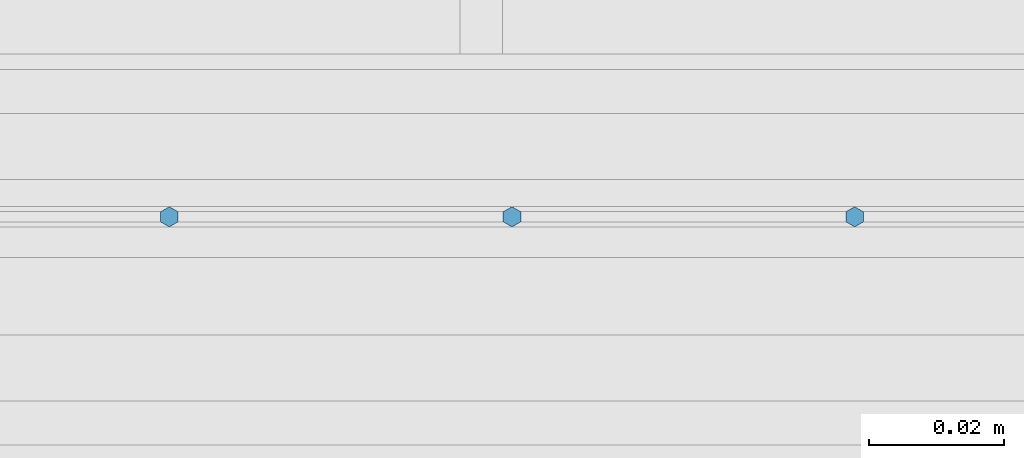
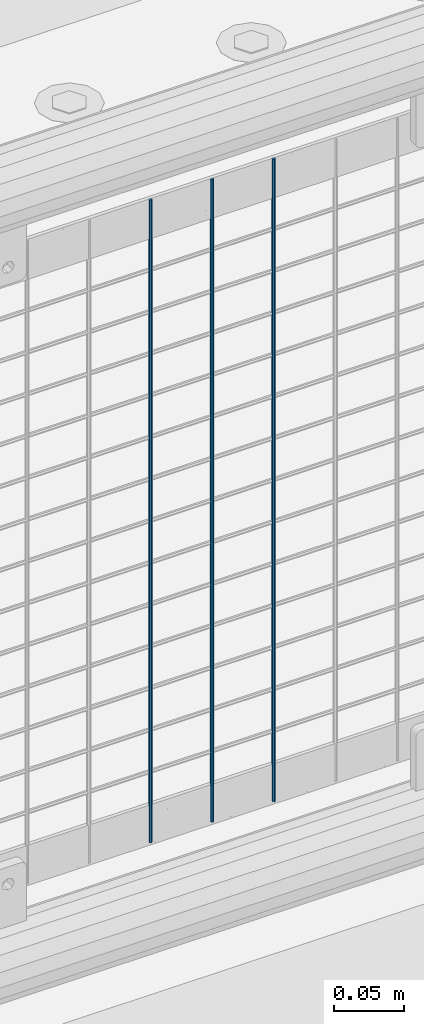
# One storey, part 91 of 270: 3 columns.
"""IFC2X3 building model written with IfcOpenShell, lengths in millimetres."""

from ifc_helpers import new_model, si_unit, frame, origin_with_axes, place, context, subcontext, project, spatial, faceted_brep, material, type_object, element, save


model = new_model("IFC2X3")

# Units and contexts
model_context = context("Model", 3, precision=1e-05, world=origin_with_axes())
body_context = subcontext(model_context, "Body", "Model", "MODEL_VIEW")
ifc_project = project(units=[si_unit("LENGTHUNIT", "METRE", prefix="MILLI"), si_unit("AREAUNIT", "SQUARE_METRE"), si_unit("VOLUMEUNIT", "CUBIC_METRE"), si_unit("MASSUNIT", "GRAM", prefix="KILO"), si_unit("TIMEUNIT", "SECOND"), si_unit("PLANEANGLEUNIT", "RADIAN"), si_unit("SOLIDANGLEUNIT", "STERADIAN"), si_unit("THERMODYNAMICTEMPERATUREUNIT", "DEGREE_CELSIUS"), si_unit("LUMINOUSINTENSITYUNIT", "LUMEN")], contexts=[model_context])

# Site, building, storey
site_placement = place(None, origin_with_axes())
site = spatial("IfcSite", under=ifc_project, at=site_placement, CompositionType="ELEMENT")
building_placement = place(site_placement, origin_with_axes())
building = spatial("IfcBuilding", under=site, at=building_placement, Name="Standard", CompositionType="ELEMENT")
storey_placement = place(building_placement, origin_with_axes())
storey = spatial("IfcBuildingStorey", under=building, at=storey_placement, Name="Undefined", CompositionType="ELEMENT", Elevation=0.0)

# Columns
ifc_material = material(Name="Misc_Undefined")
column_type = type_object("IfcColumnType", Name="D3", PredefinedType="NOTDEFINED")
for number, where, z_axis, x_axis in (
    (1, (11108.516, -16329.5, 353.02), (-1.0, 0.0, 0.0), (0.0, 0.0, 1.0)),
    (2, (11057.723, -16329.5, 353.02), (-1.0, 0.0, 0.0), (0.0, 0.0, 1.0)),
    (3, (11006.93, -16329.5, 353.02), (-1.0, 0.0, 0.0), (0.0, 0.0, 1.0)),
):
    element("IfcColumn", number, at=place(storey_placement, frame(where, z_axis=z_axis, x_axis=x_axis)), inside=storey, type_object=column_type, material=ifc_material, ObjectType="D3", context=body_context, shape_type="Brep", body=[
        faceted_brep([(0.0, -1.5, 0.0), (0.0, -0.75, -1.29903810567669), (560.0, -0.75, -1.29903810567703), (560.0, -1.5, 0.0), (0.0, 0.75, -1.29903810567669), (560.0, 0.75, -1.29903810567703), (0.0, 1.5, 0.0), (560.0, 1.5, 0.0), (0.0, 0.75, 1.29903810567669), (560.0, 0.75, 1.29903810567703), (0.0, -0.75, 1.29903810567669), (560.0, -0.75, 1.29903810567703)], [[[0, 1, 2, 3]], [[1, 4, 5, 2]], [[4, 6, 7, 5]], [[6, 8, 9, 7]], [[8, 10, 11, 9]], [[10, 0, 3, 11]], [[5, 7, 9, 11, 3, 2]], [[10, 8, 6, 4, 1, 0]]]),
    ])

save(model, "model.ifc")
